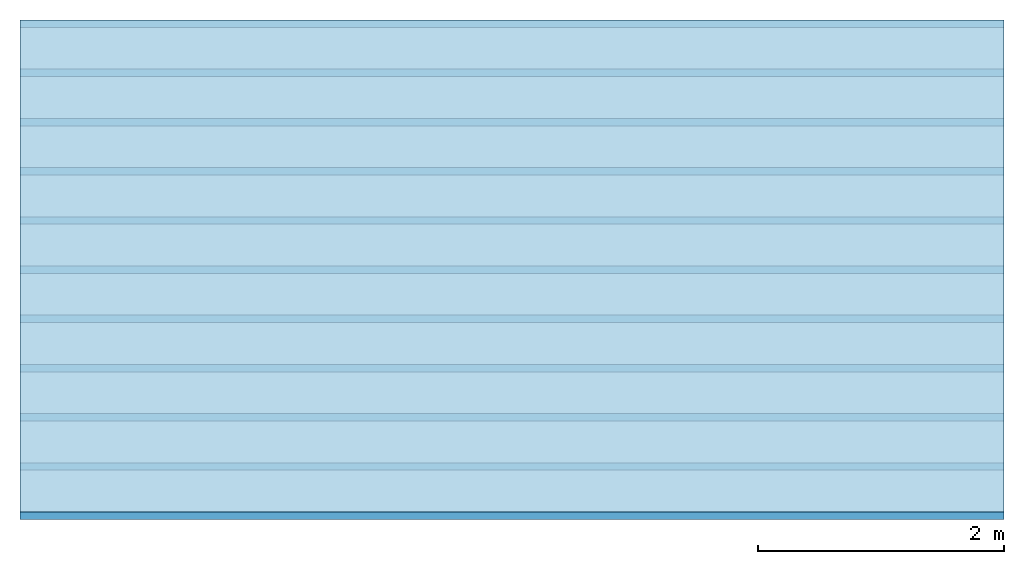
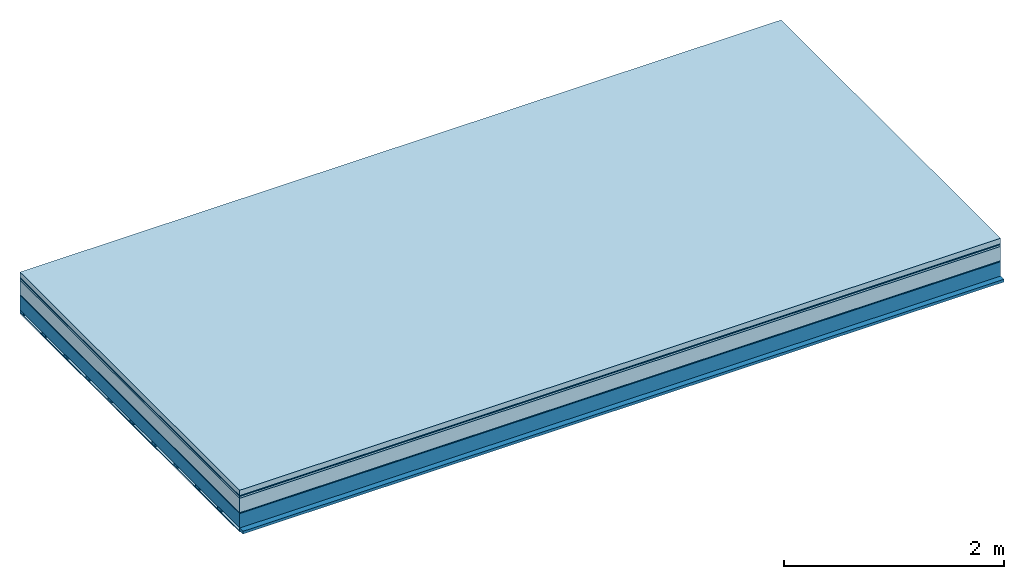
# One storey: 7 plates, 2 members, 1 element without a shape of its own.
"""IFC4 building model written with IfcOpenShell, lengths in metres."""

from ifc_helpers import new_model, si_unit, derived_unit, direction, frame, frame_2d, origin, origin_with_axes, place, context, project, spatial, rectangle, extrude, material, layer, layer_set, type_object, element, aggregate, save


model = new_model("IFC4")

# Units and contexts
plan_context = context("Plan", 3, precision=1e-05, world=origin(), true_north=direction((0.0, 1.0)))
model_context = context("Model", 3, precision=1e-05, world=origin(), true_north=direction((0.0, 1.0)))
ifc_project = project(units=[si_unit("LENGTHUNIT", "METRE"), derived_unit("SOUNDPRESSUREUNIT", [(si_unit("PRESSUREUNIT", "PASCAL", prefix="MICRO"), 0)]), si_unit("ENERGYUNIT", "JOULE", prefix="MEGA"), si_unit("MASSUNIT", "GRAM", prefix="KILO"), derived_unit("THERMALTRANSMITTANCEUNIT", [(si_unit("POWERUNIT", "WATT"), 1), (si_unit("AREAUNIT", "SQUARE_METRE"), -1), (si_unit("THERMODYNAMICTEMPERATUREUNIT", "KELVIN"), -1)]), derived_unit("AREADENSITYUNIT", [(si_unit("MASSUNIT", "GRAM", prefix="KILO"), 1), (si_unit("AREAUNIT", "SQUARE_METRE"), -1)]), derived_unit("USERDEFINED", [(si_unit("ENERGYUNIT", "JOULE", prefix="MEGA"), 1), (si_unit("AREAUNIT", "SQUARE_METRE"), -1)])], contexts=[plan_context, model_context])

# Site, building, storey
site = spatial("IfcSite", under=ifc_project)
building_placement = place(None, origin())
building = spatial("IfcBuilding", under=site, at=building_placement)
storey_placement = place(building_placement, origin())
storey = spatial("IfcBuildingStorey", under=building, at=storey_placement)

# Slab, members, plates
ifc_material_1 = material(Name="clay", Category="02.004")
ifc_layer_1 = layer(ifc_material_1, 0.06, Name="Use and protection layer 2")
ifc_material_2 = material(Name="Protective layer", Category="09.007")
ifc_layer_2 = layer(ifc_material_2, 0.01, Name="Use and protection layer 1")
ifc_material_3 = material(Name="Bituminous", Category="09.003")
ifc_layer_3 = layer(ifc_material_3, 0.02, Name="Seal")
ifc_material_4 = material(Name="Mineral wool", Category="10.008")
ifc_layer_4 = layer(ifc_material_4, 0.16, Name="Exterior insulation layer 1")
ifc_material_5 = material(Name="Vapor-permeable barrier", Category="09.006")
ifc_layer_5 = layer(ifc_material_5, 0.01, Name="layer / temporary roof")
ifc_material_6 = material(Name="no composite action")
ifc_layer_6 = layer(ifc_material_6, 0.0, Name="Bond")
ifc_layer_7 = layer(None, 0.16, Name="Support")
ifc_material_7 = material(Name="of the art")
ifc_layer_8 = layer(ifc_material_7, 0.0, Name="Bond")
ifc_layer_9 = layer(None, 0.03, Name="Battens / profiles")
ifc_material_8 = material(Name="Plasterboard type A", Category="03.008")
ifc_layer_10 = layer(ifc_material_8, 0.0125, Name="Covering below 1st layer")
ifc_material_9 = material(Category="04.001")
ifc_layer_11 = layer(ifc_material_9, 0.003, Name="Surface below")
ifc_layer_set = layer_set([ifc_layer_1, ifc_layer_2, ifc_layer_3, ifc_layer_4, ifc_layer_5, ifc_layer_6, ifc_layer_7, ifc_layer_8, ifc_layer_9, ifc_layer_10, ifc_layer_11])
slab_type = type_object("IfcSlabType", Name="F0074", PredefinedType="NOTDEFINED", material=ifc_layer_set)
slab_placement = place(None, frame((0.0, 0.0, 0.0), z_axis=(0.0, 0.0, -1.0), x_axis=(1.0, 0.0, 0.0)))
slab = element("IfcSlab", 1, at=slab_placement, inside=storey, type_object=slab_type, material=ifc_layer_set, Name="Slab #1")
ifc_material_10 = material(Name="Solid timber panel")
member_1_placement = place(slab_placement, origin())
member_1 = element("IfcMember", 2, at=member_1_placement, material=ifc_material_10, Name="Support", context=plan_context, shape_type="SweptSolid", body=[
    extrude(rectangle(XDim=1.0, YDim=0.16, at=frame_2d((0.5, 0.08), x_axis=(1.0, 0.0))), frame((0.0, 4.0, 0.26), z_axis=(0.0, -1.0, 0.0), x_axis=(1.0, 0.0, 0.0)), (0.0, 0.0, 1.0), 4.0),
    extrude(rectangle(XDim=1.0, YDim=0.16, at=frame_2d((0.5, 0.08), x_axis=(1.0, 0.0))), frame((1.0, 4.0, 0.26), z_axis=(0.0, -1.0, 0.0), x_axis=(1.0, 0.0, 0.0)), (0.0, 0.0, 1.0), 4.0),
    extrude(rectangle(XDim=1.0, YDim=0.16, at=frame_2d((0.5, 0.08), x_axis=(1.0, 0.0))), frame((2.0, 4.0, 0.26), z_axis=(0.0, -1.0, 0.0), x_axis=(1.0, 0.0, 0.0)), (0.0, 0.0, 1.0), 4.0),
    extrude(rectangle(XDim=1.0, YDim=0.16, at=frame_2d((0.5, 0.08), x_axis=(1.0, 0.0))), frame((3.0, 4.0, 0.26), z_axis=(0.0, -1.0, 0.0), x_axis=(1.0, 0.0, 0.0)), (0.0, 0.0, 1.0), 4.0),
    extrude(rectangle(XDim=1.0, YDim=0.16, at=frame_2d((0.5, 0.08), x_axis=(1.0, 0.0))), frame((4.0, 4.0, 0.26), z_axis=(0.0, -1.0, 0.0), x_axis=(1.0, 0.0, 0.0)), (0.0, 0.0, 1.0), 4.0),
    extrude(rectangle(XDim=1.0, YDim=0.16, at=frame_2d((0.5, 0.08), x_axis=(1.0, 0.0))), frame((5.0, 4.0, 0.26), z_axis=(0.0, -1.0, 0.0), x_axis=(1.0, 0.0, 0.0)), (0.0, 0.0, 1.0), 4.0),
    extrude(rectangle(XDim=1.0, YDim=0.16, at=frame_2d((0.5, 0.08), x_axis=(1.0, 0.0))), frame((6.0, 4.0, 0.26), z_axis=(0.0, -1.0, 0.0), x_axis=(1.0, 0.0, 0.0)), (0.0, 0.0, 1.0), 4.0),
    extrude(rectangle(XDim=1.0, YDim=0.16, at=frame_2d((0.5, 0.08), x_axis=(1.0, 0.0))), frame((7.0, 4.0, 0.26), z_axis=(0.0, -1.0, 0.0), x_axis=(1.0, 0.0, 0.0)), (0.0, 0.0, 1.0), 4.0),
])
ifc_material_11 = material()
member_2_placement = place(slab_placement, origin())
member_2 = element("IfcMember", 3, at=member_2_placement, material=ifc_material_11, Name="Battens / profiles", context=plan_context, shape_type="SweptSolid", body=[
    extrude(rectangle(XDim=0.06, YDim=0.03, at=frame_2d((0.03, 0.015), x_axis=(1.0, 0.0))), frame((0.0, 0.0, 0.42), z_axis=(1.0, 0.0, 0.0), x_axis=(0.0, 1.0, 0.0)), (0.0, 0.0, 1.0), 8.0),
    extrude(rectangle(XDim=0.06, YDim=0.03, at=frame_2d((0.03, 0.015), x_axis=(1.0, 0.0))), frame((0.0, 0.4, 0.42), z_axis=(1.0, 0.0, 0.0), x_axis=(0.0, 1.0, 0.0)), (0.0, 0.0, 1.0), 8.0),
    extrude(rectangle(XDim=0.06, YDim=0.03, at=frame_2d((0.03, 0.015), x_axis=(1.0, 0.0))), frame((0.0, 0.8, 0.42), z_axis=(1.0, 0.0, 0.0), x_axis=(0.0, 1.0, 0.0)), (0.0, 0.0, 1.0), 8.0),
    extrude(rectangle(XDim=0.06, YDim=0.03, at=frame_2d((0.03, 0.015), x_axis=(1.0, 0.0))), frame((0.0, 1.2, 0.42), z_axis=(1.0, 0.0, 0.0), x_axis=(0.0, 1.0, 0.0)), (0.0, 0.0, 1.0), 8.0),
    extrude(rectangle(XDim=0.06, YDim=0.03, at=frame_2d((0.03, 0.015), x_axis=(1.0, 0.0))), frame((0.0, 1.6, 0.42), z_axis=(1.0, 0.0, 0.0), x_axis=(0.0, 1.0, 0.0)), (0.0, 0.0, 1.0), 8.0),
    extrude(rectangle(XDim=0.06, YDim=0.03, at=frame_2d((0.03, 0.015), x_axis=(1.0, 0.0))), frame((0.0, 2.0, 0.42), z_axis=(1.0, 0.0, 0.0), x_axis=(0.0, 1.0, 0.0)), (0.0, 0.0, 1.0), 8.0),
    extrude(rectangle(XDim=0.06, YDim=0.03, at=frame_2d((0.03, 0.015), x_axis=(1.0, 0.0))), frame((0.0, 2.4, 0.42), z_axis=(1.0, 0.0, 0.0), x_axis=(0.0, 1.0, 0.0)), (0.0, 0.0, 1.0), 8.0),
    extrude(rectangle(XDim=0.06, YDim=0.03, at=frame_2d((0.03, 0.015), x_axis=(1.0, 0.0))), frame((0.0, 2.8, 0.42), z_axis=(1.0, 0.0, 0.0), x_axis=(0.0, 1.0, 0.0)), (0.0, 0.0, 1.0), 8.0),
    extrude(rectangle(XDim=0.06, YDim=0.03, at=frame_2d((0.03, 0.015), x_axis=(1.0, 0.0))), frame((0.0, 3.2, 0.42), z_axis=(1.0, 0.0, 0.0), x_axis=(0.0, 1.0, 0.0)), (0.0, 0.0, 1.0), 8.0),
    extrude(rectangle(XDim=0.06, YDim=0.03, at=frame_2d((0.03, 0.015), x_axis=(1.0, 0.0))), frame((0.0, 3.6, 0.42), z_axis=(1.0, 0.0, 0.0), x_axis=(0.0, 1.0, 0.0)), (0.0, 0.0, 1.0), 8.0),
    extrude(rectangle(XDim=0.06, YDim=0.03, at=frame_2d((0.03, 0.015), x_axis=(1.0, 0.0))), frame((0.0, 4.0, 0.42), z_axis=(1.0, 0.0, 0.0), x_axis=(0.0, 1.0, 0.0)), (0.0, 0.0, 1.0), 8.0),
])
plate_1_placement = place(slab_placement, origin())
plate_1 = element("IfcPlate", 4, at=plate_1_placement, material=ifc_material_1, Name="Use and protection layer 2", context=plan_context, shape_type="SweptSolid", body=[
    extrude(rectangle(XDim=8.0, YDim=4.0, at=frame_2d((4.0, 2.0), x_axis=(1.0, 0.0))), origin_with_axes(), (0.0, 0.0, 1.0), 0.06),
])
plate_2_placement = place(slab_placement, origin())
plate_2 = element("IfcPlate", 5, at=plate_2_placement, material=ifc_material_2, Name="Use and protection layer 1", context=plan_context, shape_type="SweptSolid", body=[
    extrude(rectangle(XDim=8.0, YDim=4.0, at=frame_2d((4.0, 2.0), x_axis=(1.0, 0.0))), frame((0.0, 0.0, 0.06), z_axis=(0.0, 0.0, 1.0), x_axis=(1.0, 0.0, 0.0)), (0.0, 0.0, 1.0), 0.01),
])
plate_3_placement = place(slab_placement, origin())
plate_3 = element("IfcPlate", 6, at=plate_3_placement, material=ifc_material_3, Name="Seal", context=plan_context, shape_type="SweptSolid", body=[
    extrude(rectangle(XDim=8.0, YDim=4.0, at=frame_2d((4.0, 2.0), x_axis=(1.0, 0.0))), frame((0.0, 0.0, 0.07), z_axis=(0.0, 0.0, 1.0), x_axis=(1.0, 0.0, 0.0)), (0.0, 0.0, 1.0), 0.02),
])
plate_4_placement = place(slab_placement, origin())
plate_4 = element("IfcPlate", 7, at=plate_4_placement, material=ifc_material_4, Name="Exterior insulation layer 1", context=plan_context, shape_type="SweptSolid", body=[
    extrude(rectangle(XDim=8.0, YDim=4.0, at=frame_2d((4.0, 2.0), x_axis=(1.0, 0.0))), frame((0.0, 0.0, 0.09), z_axis=(0.0, 0.0, 1.0), x_axis=(1.0, 0.0, 0.0)), (0.0, 0.0, 1.0), 0.16),
])
plate_5_placement = place(slab_placement, origin())
plate_5 = element("IfcPlate", 8, at=plate_5_placement, material=ifc_material_5, Name="layer / temporary roof", context=plan_context, shape_type="SweptSolid", body=[
    extrude(rectangle(XDim=8.0, YDim=4.0, at=frame_2d((4.0, 2.0), x_axis=(1.0, 0.0))), frame((0.0, 0.0, 0.25), z_axis=(0.0, 0.0, 1.0), x_axis=(1.0, 0.0, 0.0)), (0.0, 0.0, 1.0), 0.01),
])
plate_6_placement = place(slab_placement, origin())
plate_6 = element("IfcPlate", 9, at=plate_6_placement, material=ifc_material_8, Name="Covering below 1st layer", context=plan_context, shape_type="SweptSolid", body=[
    extrude(rectangle(XDim=8.0, YDim=4.0, at=frame_2d((4.0, 2.0), x_axis=(1.0, 0.0))), frame((0.0, 0.0, 0.45), z_axis=(0.0, 0.0, 1.0), x_axis=(1.0, 0.0, 0.0)), (0.0, 0.0, 1.0), 0.0125),
])
plate_7_placement = place(slab_placement, origin())
plate_7 = element("IfcPlate", 10, at=plate_7_placement, material=ifc_material_9, Name="Surface below", context=plan_context, shape_type="SweptSolid", body=[
    extrude(rectangle(XDim=8.0, YDim=4.0, at=frame_2d((4.0, 2.0), x_axis=(1.0, 0.0))), frame((0.0, 0.0, 0.4625), z_axis=(0.0, 0.0, 1.0), x_axis=(1.0, 0.0, 0.0)), (0.0, 0.0, 1.0), 0.003),
])
aggregate(slab, [plate_1, plate_2, plate_3, plate_4, plate_5, member_1, member_2, plate_6, plate_7])

save(model, "model.ifc")
